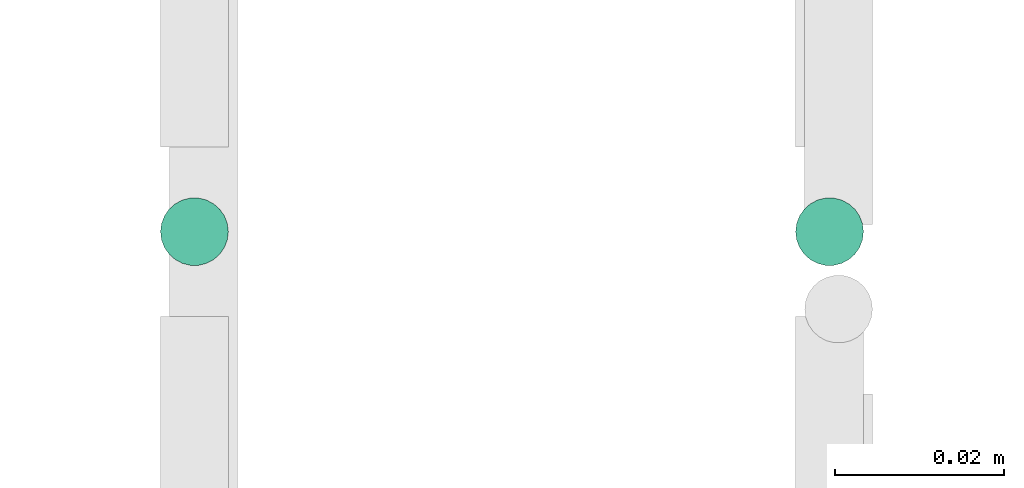
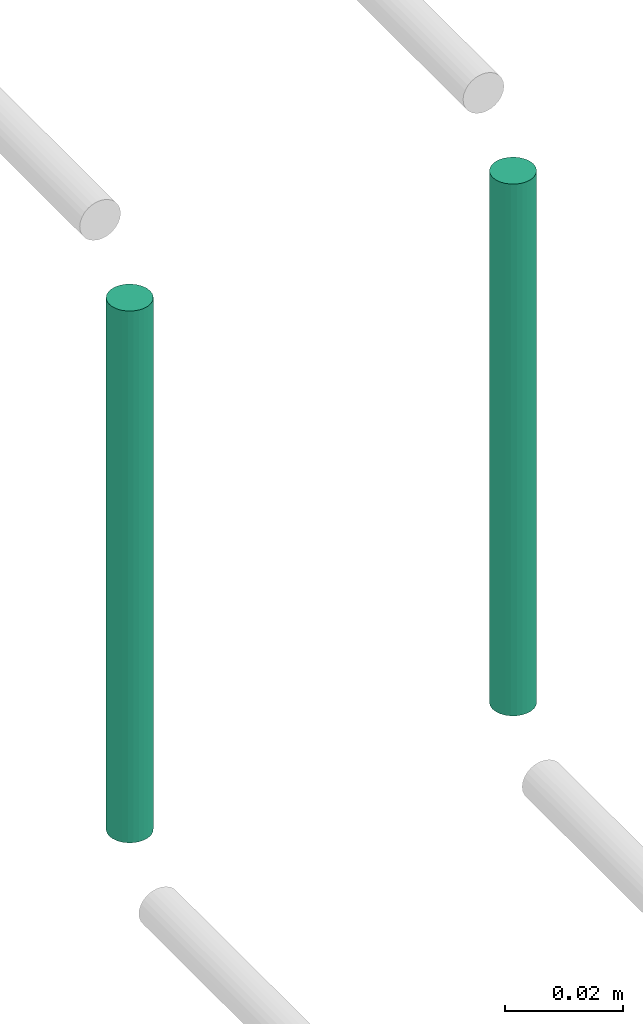
# One storey, part 184 of 331: 2 flow segments.
"""IFC2X3 building model written with IfcOpenShell, lengths in millimetres."""

import ifcopenshell
import ifcopenshell.guid

model = None  # the IFC model being written
_history = None  # IfcOwnerHistory: only IFC2X3 demands one
_inside = {}  # id of a spatial element -> (the spatial element, [elements in it])
_under = {}  # id of a project, library or spatial element -> (it, [spatial elements below it])
_declared = {}  # id of a project -> (the project, [libraries it declares])
_typed = {}  # id of a type object -> (the type object, [elements of that type])
_made_of = {}  # id of a material, layer set ... -> (it, [elements and type objects made of it])


def new_model(schema):
    """Start an empty IFC model of exactly this schema.

    Asked for "IFC4X3", IfcOpenShell would pick the latest addendum, in which some entities
    have other attributes; the version numbers below select the first issue.
    IFC2X3 requires an IfcOwnerHistory on every rooted entity: one is made here for all.
    """
    global model, _history
    if schema == "IFC4X3":
        model = ifcopenshell.file(schema_version=(4, 3, 0, 0))
    else:
        model = ifcopenshell.file(schema=schema)
    _inside.clear()
    _under.clear()
    _declared.clear()
    _typed.clear()
    _made_of.clear()
    _history = None
    if model.schema == "IFC2X3":
        org = make("IfcOrganization", Name="unknown")
        user = make(
            "IfcPersonAndOrganization",
            ThePerson=make("IfcPerson", FamilyName="unknown"),
            TheOrganization=org,
        )
        app = make(
            "IfcApplication",
            ApplicationDeveloper=org,
            Version="unknown",
            ApplicationFullName="unknown",
            ApplicationIdentifier="unknown",
        )
        _history = make(
            "IfcOwnerHistory",
            OwningUser=user,
            OwningApplication=app,
            ChangeAction="ADDED",
            CreationDate=0,
        )
    return model


def make(cls, **values):
    """One entity of the class cls with the attributes given. An attribute that is None is left unset."""
    return model.create_entity(
        cls, **{name: value for name, value in values.items() if value is not None}
    )


def entity(cls, *values):
    """Any entity or typed value of the class cls, its attributes in the order of the schema. None: left unset."""
    e = model.create_entity(cls)
    for i, value in enumerate(values):
        if value is not None:
            e[i] = value
    return e


def rooted(cls, **values):
    """An entity with a GlobalId (a new one), such as an element, a storey or a relation."""
    return make(cls, GlobalId=ifcopenshell.guid.new(), OwnerHistory=_history, **values)


def si_unit(unit_type, name, prefix=None):
    """IfcSIUnit, for example si_unit("LENGTHUNIT", "METRE", prefix="MILLI")."""
    return make("IfcSIUnit", UnitType=unit_type, Prefix=prefix, Name=name)


def converted_unit(unit_type, name, factor, base, dimensions=None, offset=None):
    """IfcConversionBasedUnit, such as the inch: factor (a typed value) times the base unit."""
    return make(
        "IfcConversionBasedUnit"
        if offset is None
        else "IfcConversionBasedUnitWithOffset",
        ConversionOffset=offset,
        Dimensions=None
        if dimensions is None
        else entity("IfcDimensionalExponents", *dimensions),
        UnitType=unit_type,
        Name=name,
        ConversionFactor=make(
            "IfcMeasureWithUnit", ValueComponent=factor, UnitComponent=base
        ),
    )


def derived_unit(unit_type, elements):
    """IfcDerivedUnit: a product of units, each with its exponent."""
    return make(
        "IfcDerivedUnit",
        Elements=[
            make("IfcDerivedUnitElement", Unit=unit, Exponent=power)
            for unit, power in elements
        ],
        UnitType=unit_type,
    )


def assignment(units):
    """IfcUnitAssignment: the units of a project."""
    return None if units is None else make("IfcUnitAssignment", Units=units)


def point(xyz):
    """IfcCartesianPoint."""
    return None if xyz is None else make("IfcCartesianPoint", Coordinates=xyz)


def direction(xyz):
    """IfcDirection."""
    return None if xyz is None else make("IfcDirection", DirectionRatios=xyz)


def frame(location, z_axis=None, x_axis=None):
    """IfcAxis2Placement3D, a coordinate frame: its origin and axes. An axis left out is left unset."""
    return make(
        "IfcAxis2Placement3D",
        Location=point(location),
        Axis=direction(z_axis),
        RefDirection=direction(x_axis),
    )


def frame_2d(location, x_axis=None):
    """IfcAxis2Placement2D, a coordinate frame in the plane: its origin and x axis."""
    return make(
        "IfcAxis2Placement2D", Location=point(location), RefDirection=direction(x_axis)
    )


def origin():
    """The frame at (0, 0, 0) with its axes left unset."""
    return frame((0.0, 0.0, 0.0))


def origin_2d_with_axis():
    """The frame at (0, 0) in the plane with the x axis (1, 0) written out."""
    return frame_2d((0.0, 0.0), x_axis=(1.0, 0.0))


def place(relative_to, where):
    """IfcLocalPlacement: puts the frame where relative to a parent placement (None: the world)."""
    return make(
        "IfcLocalPlacement", PlacementRelTo=relative_to, RelativePlacement=where
    )


def context(
    kind, dimensions, precision=None, world=None, true_north=None, identifier=None
):
    """IfcGeometricRepresentationContext, for example the 3D "Model" context."""
    return make(
        "IfcGeometricRepresentationContext",
        ContextIdentifier=identifier,
        ContextType=kind,
        CoordinateSpaceDimension=dimensions,
        Precision=precision,
        WorldCoordinateSystem=world,
        TrueNorth=true_north,
    )


def subcontext(parent, identifier, kind, view, scale=None):
    """IfcGeometricRepresentationSubContext, for example "Body" below "Model"."""
    return make(
        "IfcGeometricRepresentationSubContext",
        ContextIdentifier=identifier,
        ContextType=kind,
        ParentContext=parent,
        TargetScale=scale,
        TargetView=view,
    )


def project(units=None, contexts=None):
    """IfcProject with its units and contexts."""
    return rooted(
        "IfcProject",
        Name="project",
        RepresentationContexts=contexts,
        UnitsInContext=assignment(units),
    )


def spatial(cls, under=None, at=None, **own):
    """A site, building, storey or space (cls), placed at a placement, below another one or the project."""
    s = rooted(cls, ObjectPlacement=at, **own)
    if under is not None:
        _under.setdefault(under.id(), (under, []))[1].append(s)
    return s


def profile(cls, at=None, kind="AREA", **sizes):
    """A parametric profile (cls). Its sizes go by their IFC names, for example OverallWidth=200.0."""
    return make(cls, ProfileType=kind, Position=at, **sizes)


def circle(**sizes):
    """IfcCircleProfileDef."""
    return profile("IfcCircleProfileDef", **sizes)


def extrude(swept, where, along, depth):
    """IfcExtrudedAreaSolid: the profile swept, set in the frame where, extruded along a direction by depth."""
    return make(
        "IfcExtrudedAreaSolid",
        SweptArea=swept,
        Position=where,
        ExtrudedDirection=direction(along),
        Depth=depth,
    )


def shape(context_of_items, identifier, shape_type, items):
    """IfcShapeRepresentation: the items that make up one representation, for example the "Body"."""
    return make(
        "IfcShapeRepresentation",
        ContextOfItems=context_of_items,
        RepresentationIdentifier=identifier,
        RepresentationType=shape_type,
        Items=items,
    )


def made_of(thing, what):
    """Note that an element or type object is made of a material, layer set ...; save() writes the relation."""
    if what is not None:
        _made_of.setdefault(what.id(), (what, []))[1].append(thing)
    return thing


def type_object(cls, material=None, **own):
    """A type object (cls), such as IfcWallType, which elements share."""
    return made_of(rooted(cls, **own), material)


def element(
    cls,
    number,
    at=None,
    inside=None,
    cuts=None,
    type_object=None,
    material=None,
    context=None,
    identifier="Body",
    shape_type=None,
    held_by="IfcProductDefinitionShape",
    body=None,
    shapes=None,
    **own,
):
    """One element of the class cls, such as IfcWall. Its Tag is "e" and its number.

    at: its placement. inside: the storey or other place that contains it. cuts: it is an
    opening in that element (IfcRelVoidsElement). A single representation is given by context,
    identifier, shape_type and body (its items); several are given by shapes. held_by: the class
    of the entity that holds the representations. save() writes the other relations.
    """
    e = rooted(cls, Tag="e%d" % number, ObjectPlacement=at, **own)
    if body is not None:
        shapes = [shape(context, identifier, shape_type, body)]
    if shapes is not None:
        e.Representation = make(held_by, Representations=shapes)
    if inside is not None:
        _inside.setdefault(inside.id(), (inside, []))[1].append(e)
    if cuts is not None:
        rooted(
            "IfcRelVoidsElement", RelatingBuildingElement=cuts, RelatedOpeningElement=e
        )
    if type_object is not None:
        _typed.setdefault(type_object.id(), (type_object, []))[1].append(e)
    return made_of(e, material)


def aggregate(whole, parts):
    """IfcRelAggregates: a whole, such as a stair, and the parts it consists of."""
    return rooted("IfcRelAggregates", RelatingObject=whole, RelatedObjects=parts)


def save(model, path):
    """Write the relations noted so far, then the file.

    IfcRelAggregates (storeys below a building ...), IfcRelContainedInSpatialStructure (elements
    in a storey), IfcRelDefinesByType, IfcRelAssociatesMaterial and IfcRelDeclares: one each for
    every whole, place, type object, material and project.
    """
    for whole, parts in _under.values():
        aggregate(whole, parts)
    for where, things in _inside.values():
        rooted(
            "IfcRelContainedInSpatialStructure",
            RelatedElements=things,
            RelatingStructure=where,
        )
    for kind, things in _typed.values():
        rooted("IfcRelDefinesByType", RelatedObjects=things, RelatingType=kind)
    for what, things in _made_of.values():
        rooted("IfcRelAssociatesMaterial", RelatedObjects=things, RelatingMaterial=what)
    for by, libraries in _declared.values():
        rooted("IfcRelDeclares", RelatingContext=by, RelatedDefinitions=libraries)
    model.write(path)


model = new_model("IFC2X3")

# Units and contexts
model_context = context("Model", 3, precision=0.01, world=origin(), true_north=direction((6.12303176911189e-17, 1.0)))
body_context = subcontext(model_context, "Body", "Model", "MODEL_VIEW")
ifc_project = project(units=[si_unit("LENGTHUNIT", "METRE", prefix="MILLI"), si_unit("AREAUNIT", "SQUARE_METRE"), si_unit("VOLUMEUNIT", "CUBIC_METRE"), converted_unit("PLANEANGLEUNIT", "DEGREE", entity("IfcRatioMeasure", 0.0174532925199433), si_unit("PLANEANGLEUNIT", "RADIAN"), dimensions=[0, 0, 0, 0, 0, 0, 0]), si_unit("MASSUNIT", "GRAM", prefix="KILO"), derived_unit("MASSDENSITYUNIT", [(si_unit("MASSUNIT", "GRAM", prefix="KILO"), 1), (si_unit("LENGTHUNIT", "METRE"), -3)]), derived_unit("MOMENTOFINERTIAUNIT", [(si_unit("LENGTHUNIT", "METRE"), 4)]), si_unit("TIMEUNIT", "SECOND"), si_unit("FREQUENCYUNIT", "HERTZ"), si_unit("THERMODYNAMICTEMPERATUREUNIT", "DEGREE_CELSIUS"), derived_unit("THERMALTRANSMITTANCEUNIT", [(si_unit("MASSUNIT", "GRAM", prefix="KILO"), 1), (si_unit("THERMODYNAMICTEMPERATUREUNIT", "KELVIN"), -1), (si_unit("TIMEUNIT", "SECOND"), -3)]), derived_unit("VOLUMETRICFLOWRATEUNIT", [(si_unit("LENGTHUNIT", "METRE"), 3), (si_unit("TIMEUNIT", "SECOND"), -1)]), derived_unit("MASSFLOWRATEUNIT", [(si_unit("MASSUNIT", "GRAM", prefix="KILO"), 1), (si_unit("TIMEUNIT", "SECOND"), -1)]), derived_unit("ROTATIONALFREQUENCYUNIT", [(si_unit("TIMEUNIT", "SECOND"), -1)]), si_unit("ELECTRICCURRENTUNIT", "AMPERE"), si_unit("ELECTRICVOLTAGEUNIT", "VOLT"), si_unit("POWERUNIT", "WATT"), si_unit("FORCEUNIT", "NEWTON", prefix="KILO"), si_unit("ILLUMINANCEUNIT", "LUX"), si_unit("LUMINOUSFLUXUNIT", "LUMEN"), si_unit("LUMINOUSINTENSITYUNIT", "CANDELA"), derived_unit("USERDEFINED", [(si_unit("MASSUNIT", "GRAM", prefix="KILO"), -1), (si_unit("LENGTHUNIT", "METRE"), -2), (si_unit("TIMEUNIT", "SECOND"), 3), (si_unit("LUMINOUSFLUXUNIT", "LUMEN"), 1)]), derived_unit("LINEARVELOCITYUNIT", [(si_unit("LENGTHUNIT", "METRE"), 1), (si_unit("TIMEUNIT", "SECOND"), -1)]), si_unit("PRESSUREUNIT", "PASCAL"), derived_unit("USERDEFINED", [(si_unit("LENGTHUNIT", "METRE"), -2), (si_unit("MASSUNIT", "GRAM", prefix="KILO"), 1), (si_unit("TIMEUNIT", "SECOND"), -2)]), derived_unit("LINEARFORCEUNIT", [(si_unit("MASSUNIT", "GRAM", prefix="KILO"), 1), (si_unit("LENGTHUNIT", "METRE"), 1), (si_unit("TIMEUNIT", "SECOND"), -2), (si_unit("LENGTHUNIT", "METRE"), -1)]), derived_unit("PLANARFORCEUNIT", [(si_unit("MASSUNIT", "GRAM", prefix="KILO"), 1), (si_unit("LENGTHUNIT", "METRE"), 1), (si_unit("TIMEUNIT", "SECOND"), -2), (si_unit("LENGTHUNIT", "METRE"), -2)])], contexts=[model_context])

# Site, building, storey
site_placement = place(None, frame((0.0, -0.00077364408347762, 0.0)))
site = spatial("IfcSite", under=ifc_project, at=site_placement, CompositionType="ELEMENT")
building_placement = place(site_placement, origin())
building = spatial("IfcBuilding", under=site, at=building_placement, CompositionType="ELEMENT")
storey_placement = place(building_placement, origin())
storey = spatial("IfcBuildingStorey", under=building, at=storey_placement, CompositionType="ELEMENT", Elevation=0.0)

# Flow segments
pipe_segment_type = type_object("IfcPipeSegmentType", PredefinedType="NOTDEFINED")
flow_segment_1_placement = place(storey_placement, frame((43464.4468045266, 8084.55353441896, 18460.0)))
element("IfcFlowSegment", 1, at=flow_segment_1_placement, inside=storey, type_object=pipe_segment_type, context=body_context, shape_type="SweptSolid", body=[
    extrude(circle(Radius=4.0, at=frame_2d((0.0, -1.08286712929839e-12), x_axis=(1.0, 0.0))), frame((5.59527223591499, 5.59527223591499, 0.0), z_axis=(0.0, 0.0, 1.0), x_axis=(-1.0, 0.0, 0.0)), (0.0, 0.0, 1.0), 110.000000000014),
])
flow_segment_2_placement = place(building_placement, frame((43539.4468045266, 8084.55353441895, 18460.0)))
element("IfcFlowSegment", 2, at=flow_segment_2_placement, inside=storey, type_object=pipe_segment_type, context=body_context, shape_type="SweptSolid", body=[
    extrude(circle(Radius=4.0, at=origin_2d_with_axis()), frame((5.59527223591499, 5.59527223591607, 0.0)), (0.0, 0.0, 1.0), 110.00000000001),
])

save(model, "model.ifc")
